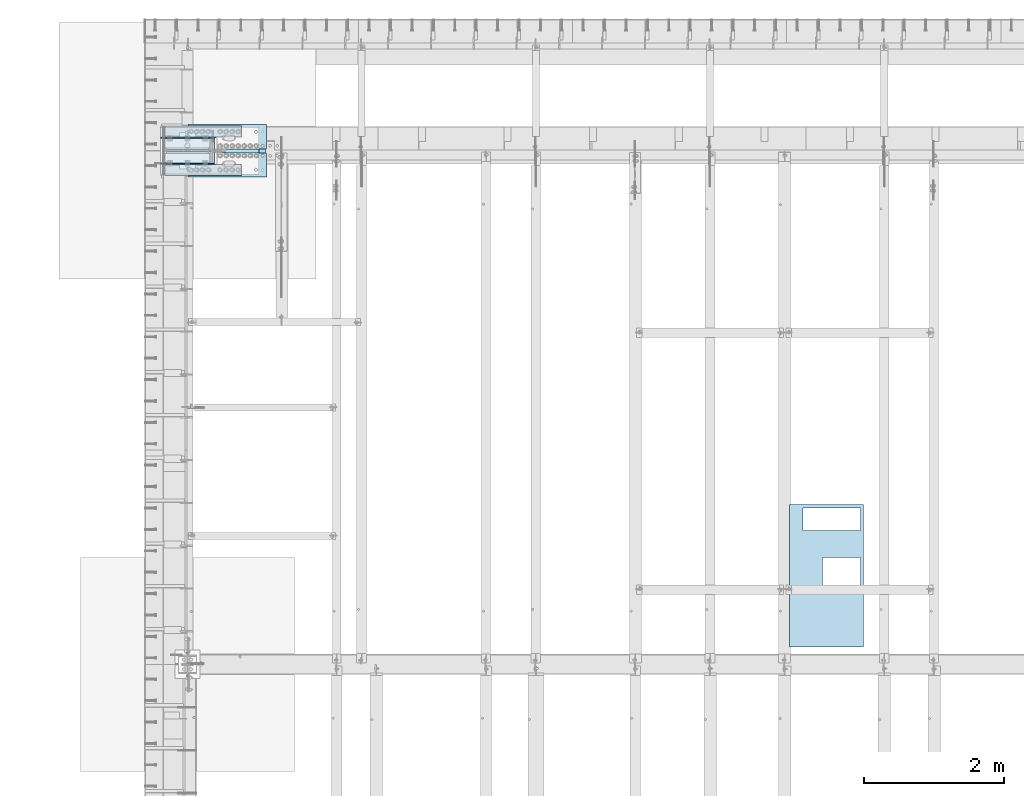
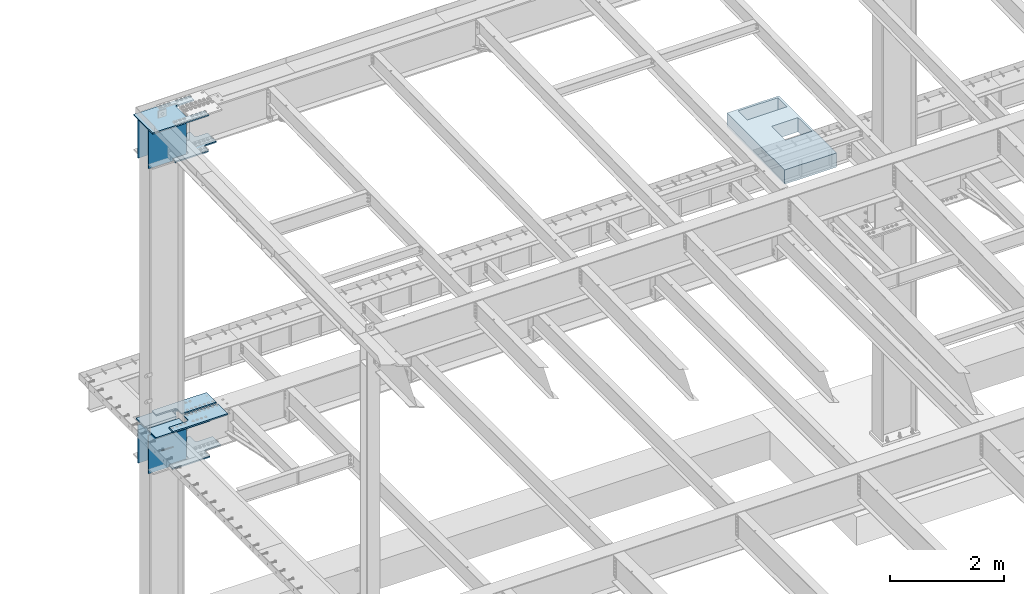
# One storey, part 1419 of 1763: 12 plates, 6 elements without a shape of their own.
"""IFC2X3 building model written with IfcOpenShell, lengths in millimetres."""

from ifc_helpers import new_model, si_unit, frame, origin_with_axes, place, context, subcontext, project, spatial, faceted_brep, material, type_object, element, aggregate, save


model = new_model("IFC2X3")

# Units and contexts
model_context = context("Model", 3, precision=1e-05, world=origin_with_axes())
body_context = subcontext(model_context, "Body", "Model", "MODEL_VIEW")
ifc_project = project(units=[si_unit("LENGTHUNIT", "METRE", prefix="MILLI"), si_unit("AREAUNIT", "SQUARE_METRE"), si_unit("VOLUMEUNIT", "CUBIC_METRE"), si_unit("MASSUNIT", "GRAM", prefix="KILO"), si_unit("TIMEUNIT", "SECOND"), si_unit("PLANEANGLEUNIT", "RADIAN"), si_unit("SOLIDANGLEUNIT", "STERADIAN"), si_unit("THERMODYNAMICTEMPERATUREUNIT", "DEGREE_CELSIUS"), si_unit("LUMINOUSINTENSITYUNIT", "LUMEN")], contexts=[model_context])

# Site, building, storey
site_placement = place(None, origin_with_axes())
site = spatial("IfcSite", under=ifc_project, at=site_placement, CompositionType="ELEMENT")
building_placement = place(site_placement, origin_with_axes())
building = spatial("IfcBuilding", under=site, at=building_placement, Name="Undefined", CompositionType="ELEMENT")
storey_placement = place(building_placement, origin_with_axes())
storey = spatial("IfcBuildingStorey", under=building, at=storey_placement, Name="Undefined", CompositionType="ELEMENT", Elevation=0.0)

# Assembly, plate
assembly_1_placement = place(storey_placement, origin_with_axes())
assembly_1 = element("IfcElementAssembly", 1, at=assembly_1_placement, inside=storey, Name="A-BOX", AssemblyPlace="NOTDEFINED", PredefinedType="RIGID_FRAME")
ifc_material_1 = material(Name="STEEL/A36")
plate_type_1 = type_object("IfcPlateType", PredefinedType="NOTDEFINED")
plate_1_placement = place(assembly_1_placement, frame((-77748.9366844177, 47081.685353399, 11747.5), z_axis=(0.0, -1.0, 0.0), x_axis=(-1.0, 0.0, 0.0)))
plate_1 = element("IfcPlate", 2, at=plate_1_placement, type_object=plate_type_1, material=ifc_material_1, Name="A-BOX", context=body_context, shape_type="Brep", body=[
    faceted_brep([(581.024999999994, -152.4, 1230.75092269852), (581.024999999994, 152.4, 1230.75092269852), (581.024999999994, 152.4, 749.303901214145), (581.024999999994, -152.4, 749.303901214145), (44.4499877929629, 152.4, 749.303901214145), (44.4499877929629, -152.4, 749.303901214145), (44.4499877929629, 152.4, 1235.07888175919), (44.4499877929629, -152.4, 1235.07888175919), (581.024999999994, 152.4, 1235.07888175919), (581.024999999994, -152.4, 1235.07888175919), (1054.09997558594, -152.4, 0.0), (0.0, -152.4, 0.0), (0.0, 152.4, 0.0), (1054.09997558594, 152.4, 0.0), (1054.09997558594, -152.4, 2025.64990234375), (1054.09997558594, 152.4, 2025.64990234375), (0.0, -152.4, 2025.64990234375), (0.0, 152.4, 2025.64990234375), (44.4499999999971, -152.4, 44.4499999999971), (44.4499999999971, -152.4, 365.128863525388), (857.241015624997, -152.4, 365.128863525388), (857.241015624997, -152.4, 44.4499999999971), (44.4499999999971, 152.4, 44.4499999999971), (44.4499999999971, 152.4, 365.128863525388), (857.241015624997, 152.4, 44.4499999999971), (857.241015624997, 152.4, 365.128863525388)], [[[0, 1, 2, 3]], [[3, 2, 4, 5]], [[5, 4, 6, 7]], [[7, 6, 8, 9]], [[9, 8, 1, 0]], [[10, 11, 12, 13]], [[14, 10, 13, 15]], [[16, 14, 15, 17]], [[11, 16, 17, 12]], [[10, 14, 16, 11], [3, 5, 7, 9, 0], [18, 19, 20, 21]], [[18, 22, 23, 19]], [[21, 24, 22, 18]], [[20, 25, 24, 21]], [[19, 23, 25, 20]], [[15, 13, 12, 17], [4, 2, 1, 8, 6], [22, 24, 25, 23]]]),
])
aggregate(assembly_1, [plate_1])

# Assembly, plates
assembly_2_placement = place(storey_placement, origin_with_axes())
assembly_2 = element("IfcElementAssembly", 3, at=assembly_2_placement, inside=storey, Name="COLUMN", AssemblyPlace="NOTDEFINED", PredefinedType="RIGID_FRAME")
ifc_material_2 = material(Name="STEEL/A572-50")
plate_type_2 = type_object("IfcPlateType", PredefinedType="NOTDEFINED")
plate_2_placement = place(assembly_2_placement, frame((-87697.6997742445, 52130.325, 5180.01249999526), z_axis=(1.0, 0.0, 0.0), x_axis=(0.0, 1.0, 0.0)))
plate_2 = element("IfcPlate", 4, at=plate_2_placement, type_object=plate_type_2, material=ifc_material_2, Name="PLATE", context=body_context, shape_type="Brep", body=[
    faceted_brep([(342.899993896484, 14.2875000000004, 0.0), (342.899993896484, -14.2875000000004, 0.0), (38.0999984740847, -14.2875000000004, 3.44835279975086e-05), (38.0999984740847, 14.2875000000004, 0.0), (342.899993896484, -14.2875000000004, 1092.20007324219), (342.899993896484, 14.2875000000004, 1092.20007324219), (184.149993896484, 14.2875000000004, 1092.20007324219), (184.149993896484, -14.2875000000004, 1092.20006477094), (184.150003540068, 14.2875000000004, 657.22498610086), (184.150003540068, -14.2875000000004, 657.22498610086), (183.183273642404, 14.2875000000004, 652.364906361428), (183.183273642404, -14.2875000000004, 652.364906361428), (180.43025961001, 14.2875000000004, 648.24472972611), (180.43025961001, -14.2875000000004, 648.24472972611), (176.310082909098, 14.2875000000004, 645.491715791897), (176.310082909098, -14.2875000000004, 645.491715791897), (171.450003146623, 14.2875000000004, 644.52498601003), (171.450003146623, -14.2875000000004, 644.52498601003), (38.1000246132753, 14.2875000056511, 644.524992143954), (38.1000246132753, -14.2875000000004, 644.524959412971), (28.5750000867774, 14.2875000059566, 634.999971765254), (7.27595761418343e-12, -14.2875000000004, 606.424995419206), (0.0, -14.2875000000004, 38.0999984772934), (28.575000080913, 14.2875000000986, 9.52499494639051)], [[[0, 1, 2, 3]], [[4, 1, 0, 5]], [[4, 5, 6, 7]], [[7, 6, 8, 9]], [[9, 8, 10, 11]], [[11, 10, 12, 13]], [[13, 12, 14, 15]], [[15, 14, 16, 17]], [[17, 16, 18, 19]], [[19, 18, 20, 21]], [[2, 1, 4, 7, 9, 11, 13, 15, 17, 19, 21, 22]], [[3, 2, 22, 23]], [[18, 16, 14, 12, 10, 8, 6, 5, 0, 3, 23, 20]], [[22, 21, 20, 23]]]),
])
plate_3_placement = place(assembly_2_placement, frame((-87697.6997742445, 52111.275, 5180.01249999526), z_axis=(1.0, 0.0, 0.0), x_axis=(0.0, -1.0, 0.0)))
plate_3 = element("IfcPlate", 5, at=plate_3_placement, type_object=plate_type_2, material=ifc_material_2, Name="PLATE", context=body_context, shape_type="Brep", body=[
    faceted_brep([(342.899993896484, 14.2875000000004, 0.0), (342.899993896484, -14.2875000000004, 0.0), (38.0999984740847, -14.2875000000004, 3.44835279975086e-05), (38.0999984740847, 14.2875000000004, 0.0), (342.899993896484, -14.2875000000004, 1092.20007324219), (342.899993896484, 14.2875000000004, 1092.20007324219), (184.149993896484, 14.2875000000004, 1092.20007324219), (184.149993896484, -14.2875000000004, 1092.20006477094), (184.150003540068, 14.2875000000004, 657.22498610086), (184.150003540068, -14.2875000000004, 657.22498610086), (183.183273642404, 14.2875000000004, 652.364906361428), (183.183273642404, -14.2875000000004, 652.364906361428), (180.43025961001, 14.2875000000004, 648.24472972611), (180.43025961001, -14.2875000000004, 648.24472972611), (176.310082909098, 14.2875000000004, 645.491715791897), (176.310082909098, -14.2875000000004, 645.491715791897), (171.450003146623, 14.2875000000004, 644.52498601003), (171.450003146623, -14.2875000000004, 644.52498601003), (38.1000246132753, 14.2875000056511, 644.524992143954), (38.1000246132753, -14.2875000000004, 644.524959412971), (28.5750000866901, -14.2875000058648, 634.9999521266), (28.5750000809203, -14.2875000000968, 9.52501563653641), (0.0, 14.2875000000004, 38.0999984772934), (7.27595761418343e-12, 14.2875000000004, 606.424995419206)], [[[0, 1, 2, 3]], [[4, 1, 0, 5]], [[4, 5, 6, 7]], [[7, 6, 8, 9]], [[9, 8, 10, 11]], [[11, 10, 12, 13]], [[13, 12, 14, 15]], [[15, 14, 16, 17]], [[17, 16, 18, 19]], [[2, 1, 4, 7, 9, 11, 13, 15, 17, 19, 20, 21]], [[3, 2, 21, 22]], [[18, 16, 14, 12, 10, 8, 6, 5, 0, 3, 22, 23]], [[19, 18, 23, 20]], [[22, 21, 20, 23]]]),
])
plate_type_3 = type_object("IfcPlateType", PredefinedType="NOTDEFINED")
plate_4_placement = place(assembly_2_placement, frame((-86615.0247736984, 51787.4250002128, 11733.2124917654), z_axis=(-1.0, 0.0, 0.0), x_axis=(0.0, 1.0, 0.0)))
plate_4 = element("IfcPlate", 6, at=plate_4_placement, type_object=plate_type_3, material=ifc_material_2, Name="PLATE", context=body_context, shape_type="Brep", body=[
    faceted_brep([(139.700000000004, -14.2875000000004, 0.0), (139.700000000004, 14.2875000000004, 0.0), (139.700000352379, 14.2875000000004, 352.425012588552), (139.700000352379, -14.2875000000004, 352.425012588552), (141.63346020726, 14.2875000000004, 362.145171622687), (141.63346020726, -14.2875000000004, 362.145171622687), (147.139488016437, 14.2875000000004, 370.38552455348), (147.139488016437, -14.2875000000004, 370.38552455348), (155.379840958223, 14.2875000000004, 375.891552346206), (155.379840958223, -14.2875000000004, 375.891552346206), (165.099999996222, 14.2875000000004, 377.825012181682), (165.099999996222, -14.2875000000004, 377.825012181682), (501.650006861608, 14.2875000000004, 377.825011846209), (501.650006861608, -14.2875000000004, 377.825011846209), (511.370165895773, 14.2875000000004, 375.891551991343), (511.370165895773, -14.2875000000004, 375.891551991343), (519.610518826594, 14.2875000000004, 370.385524182173), (519.610518826594, -14.2875000000004, 370.385524182173), (525.116546619334, 14.2875000000004, 362.14517124038), (525.116546619334, -14.2875000000004, 362.14517124038), (527.050006454818, -14.2875000000004, 352.425012202359), (527.050006454818, 14.2875000000004, 352.425012202359), (527.05000610352, 14.2875000000004, -1.45519152283669e-11), (527.05000610352, -14.2875000000004, -1.45519152283669e-11), (0.0, -14.2875000000058, 0.0), (0.0, -14.2875000000004, 1143.0), (0.0, 14.2875000000004, 1143.0), (0.0, 14.2875000000058, 0.0), (666.75, -14.2875000000004, 1143.0), (666.75, 14.2875000000004, 1143.0), (666.75, -14.2875000000004, -1.45519152283669e-11), (666.75, 14.2875000000004, -1.45519152283669e-11)], [[[0, 1, 2, 3]], [[3, 2, 4, 5]], [[5, 4, 6, 7]], [[7, 6, 8, 9]], [[9, 8, 10, 11]], [[11, 10, 12, 13]], [[13, 12, 14, 15]], [[15, 14, 16, 17]], [[17, 16, 18, 19]], [[20, 21, 22, 23]], [[19, 18, 21, 20]], [[24, 25, 26, 27]], [[25, 28, 29, 26]], [[28, 30, 31, 29]], [[31, 30, 23, 22]], [[16, 14, 12, 10, 8, 6, 4, 2, 1, 27, 26, 29, 31, 22, 21, 18]], [[24, 27, 1, 0]], [[30, 28, 25, 24, 0, 3, 5, 7, 9, 11, 13, 15, 17, 19, 20, 23]]]),
])

# Assembly, plate
assembly_3_placement = place(storey_placement, origin_with_axes())
assembly_3 = element("IfcElementAssembly", 7, at=assembly_3_placement, inside=storey, Name="PLATE", AssemblyPlace="NOTDEFINED", PredefinedType="RIGID_FRAME")
plate_type_4 = type_object("IfcPlateType", PredefinedType="NOTDEFINED")
plate_5_placement = place(assembly_3_placement, frame((-87294.4747736984, 51793.7750002128, 10955.3374917654), z_axis=(0.0, 1.0, 0.0), x_axis=(1.0, 0.0, 0.0)))
plate_5 = element("IfcPlate", 8, at=plate_5_placement, type_object=plate_type_4, material=ifc_material_2, Name="PLATE", context=body_context, shape_type="Brep", body=[
    faceted_brep([(0.0, -14.2875000000058, 0.0), (0.0, -14.2875000000004, 104.775001525879), (0.0, 14.2875000000004, 104.775001525879), (0.0, 14.2875000000058, 0.0), (300.037487030029, -14.2875000000004, 104.775001525879), (300.037487030029, 14.2875000000004, 104.775001525879), (311.320470272905, -14.2875000000004, 106.562050511995), (311.320470272905, 14.2875000000004, 106.562050511995), (321.4989965028, -14.2875000000004, 111.748268664473), (321.4989965028, 14.2875000000004, 111.748268664473), (329.576720654375, -14.2875000000004, 119.825992816048), (329.576720654375, 14.2875000000004, 119.825992816048), (334.762938806853, -14.2875000000004, 130.004519045942), (334.762938806853, 14.2875000000004, 130.004519045942), (336.549987792969, -14.2875000000004, 141.287502288818), (336.549987792969, 14.2875000000004, 141.287502288818), (336.549987792969, -14.2875000000004, 512.762523651123), (336.549987792969, 14.2875000000004, 512.762523651123), (334.762938806853, -14.2875000000004, 524.045506893999), (334.762938806853, 14.2875000000004, 524.045506893999), (329.576720654375, -14.2875000000004, 534.224033123894), (329.576720654375, 14.2875000000004, 534.224033123894), (321.4989965028, -14.2875000000004, 542.301757275469), (321.4989965028, 14.2875000000004, 542.301757275469), (311.320470272905, -14.2875000000004, 547.487975427946), (311.320470272905, 14.2875000000004, 547.487975427946), (300.037487030029, -14.2875000000004, 549.275024414062), (300.037487030029, 14.2875000000004, 549.275024414062), (0.0, -14.2875000000004, 549.275024414062), (0.0, 14.2875000000004, 549.275024414062), (0.0, -14.2875000000004, 654.049987792969), (0.0, 14.2875000000004, 654.049987792969), (679.450012207031, -14.2875000000004, 654.049987792969), (679.450012207031, 14.2875000000004, 654.049987792969), (679.450012207031, -14.2875000000004, 512.762500762939), (679.450012207031, 14.2875000000004, 512.762500762939), (681.237061193147, -14.2875000000004, 501.479517520063), (681.237061193147, 14.2875000000004, 501.479517520063), (686.423279345625, -14.2875000000004, 491.300991290169), (686.423279345625, 14.2875000000004, 491.300991290169), (694.5010034972, -14.2875000000004, 483.223267138594), (694.5010034972, 14.2875000000004, 483.223267138594), (704.679529727095, -14.2875000000004, 478.037048986116), (704.679529727095, 14.2875000000004, 478.037048986116), (715.962512969971, -14.2875000000004, 476.25), (715.962512969971, 14.2875000000004, 476.25), (936.625, -14.2875000000004, 476.25), (936.625, 14.2875000000004, 476.25), (936.625, -14.2875000000004, 177.800003051758), (936.625, 14.2875000000004, 177.800003051758), (715.962512969971, -14.2875000000004, 177.800003051758), (715.962512969971, 14.2875000000004, 177.800003051758), (704.679529727095, -14.2875000000004, 176.012954065642), (704.679529727095, 14.2875000000004, 176.012954065642), (694.5010034972, -14.2875000000004, 170.826735913164), (694.5010034972, 14.2875000000004, 170.826735913164), (686.423279345625, -14.2875000000004, 162.749011761589), (686.423279345625, 14.2875000000004, 162.749011761589), (681.237061193147, -14.2875000000004, 152.570485531694), (681.237061193147, 14.2875000000004, 152.570485531694), (679.450012207031, -14.2875000000004, 141.287502288818), (679.450012207031, 14.2875000000004, 141.287502288818), (679.450012207031, -14.2875000000004, 0.0), (679.450012207031, 14.2875000000004, 0.0)], [[[0, 1, 2, 3]], [[1, 4, 5, 2]], [[4, 6, 7, 5]], [[6, 8, 9, 7]], [[8, 10, 11, 9]], [[10, 12, 13, 11]], [[12, 14, 15, 13]], [[14, 16, 17, 15]], [[16, 18, 19, 17]], [[18, 20, 21, 19]], [[20, 22, 23, 21]], [[22, 24, 25, 23]], [[24, 26, 27, 25]], [[26, 28, 29, 27]], [[28, 30, 31, 29]], [[30, 32, 33, 31]], [[32, 34, 35, 33]], [[34, 36, 37, 35]], [[36, 38, 39, 37]], [[38, 40, 41, 39]], [[40, 42, 43, 41]], [[42, 44, 45, 43]], [[44, 46, 47, 45]], [[46, 48, 49, 47]], [[48, 50, 51, 49]], [[50, 52, 53, 51]], [[52, 54, 55, 53]], [[54, 56, 57, 55]], [[56, 58, 59, 57]], [[58, 60, 61, 59]], [[60, 62, 63, 61]], [[62, 0, 3, 63]], [[5, 7, 9, 11, 13, 15, 17, 19, 21, 23, 25, 27, 29, 31, 33, 35, 37, 39, 41, 43, 45, 47, 49, 51, 53, 55, 57, 59, 61, 63, 3, 2]], [[62, 60, 58, 56, 54, 52, 50, 48, 46, 44, 42, 40, 38, 36, 34, 32, 30, 28, 26, 24, 22, 20, 18, 16, 14, 12, 10, 8, 6, 4, 1, 0]]]),
])
aggregate(assembly_3, [plate_5])

# Plate
plate_type_5 = type_object("IfcPlateType", PredefinedType="NOTDEFINED")
plate_6_placement = place(assembly_2_placement, frame((-86992.8497859054, 52306.5375, 11718.9249917654), z_axis=(0.0, 0.0, -1.0), x_axis=(-1.0, 0.0, 0.0)))
plate_6 = element("IfcPlate", 9, at=plate_6_placement, type_object=plate_type_5, material=ifc_material_2, Name="COVER PLATE", context=body_context, shape_type="Brep", body=[
    faceted_brep([(-7.27595761418343e-12, -7.9375, 0.0), (-1.2191194400657e-05, -7.9375, 825.5), (-1.2191194400657e-05, 7.9375, 825.5), (-7.27595761418343e-12, 7.9375, 0.0), (765.174987792969, -7.9375, 825.5), (765.174987792969, 7.9375, 825.5), (765.174987792969, -7.9375, 0.0), (765.174987792969, 7.9375, 0.0)], [[[0, 1, 2, 3]], [[1, 4, 5, 2]], [[4, 6, 7, 5]], [[6, 0, 3, 7]], [[5, 7, 3, 2]], [[6, 4, 1, 0]]]),
])

plate_7_placement = place(assembly_2_placement, frame((-86992.8497859054, 51935.0625, 11718.9249917654), z_axis=(0.0, 0.0, -1.0), x_axis=(-1.0, 0.0, 0.0)))
plate_7 = element("IfcPlate", 10, at=plate_7_placement, type_object=plate_type_5, material=ifc_material_2, Name="COVER PLATE", context=body_context, shape_type="Brep", body=[
    faceted_brep([(-7.27595761418343e-12, -7.9375, 0.0), (-1.2191194400657e-05, -7.9375, 825.5), (-1.2191194400657e-05, 7.9375, 825.5), (-7.27595761418343e-12, 7.9375, 0.0), (765.174987792969, -7.9375, 825.5), (765.174987792969, 7.9375, 825.5), (765.174987792969, -7.9375, 0.0), (765.174987792969, 7.9375, 0.0)], [[[0, 1, 2, 3]], [[1, 4, 5, 2]], [[4, 6, 7, 5]], [[6, 0, 3, 7]], [[5, 7, 3, 2]], [[6, 4, 1, 0]]]),
])

plate_8_placement = place(assembly_2_placement, frame((-86992.8497736984, 52306.5375, 5165.725), z_axis=(0.0, 0.0, -1.0), x_axis=(-1.0, 0.0, 0.0)))
plate_8 = element("IfcPlate", 11, at=plate_8_placement, type_object=plate_type_5, material=ifc_material_2, Name="COVER PLATE", context=body_context, shape_type="Brep", body=[
    faceted_brep([(19.0499815529183, 7.93750682487007, 15.8750000047403), (19.0499815529183, -7.9375, 0.0), (19.0499815529183, 7.9375, 0.0), (79.37498155293, 7.93750682487007, 15.8750000047403), (79.37498155293, -7.9375, 0.0), (-7.27595761418343e-12, -7.9375, 0.0), (-7.27595761418343e-12, 7.9375, 0.0), (0.0, -7.9375, 822.324951171875), (0.0, 7.9375, 822.324951171875), (765.174987792969, -7.9375, 822.324951171875), (765.174987792969, 7.9375, 822.324951171875), (765.174987792969, -7.9375, 0.0), (765.174987792969, 7.9375, 0.0), (685.799981552918, -7.9375, 0.0), (685.799981552918, 7.9375, 0.0), (685.799981552918, 7.93750682487007, 15.8750000047403), (504.745217649033, 7.9375, 423.782724431523), (501.140063123385, 7.9375, 426.191611671965), (496.887493408227, 7.9375, 427.037500381452), (268.287496841454, 7.9375, 427.037500381452), (264.034927126311, 7.9375, 426.191611671965), (260.429772600648, 7.9375, 423.782724431523), (258.020885360209, 7.9375, 420.177569905865), (257.17499665072, 7.9375, 415.925000190718), (258.020885360209, 7.9375, 411.672430475577), (260.429772600648, 7.9375, 408.06727594992), (264.034927126311, 7.9375, 405.658388709478), (268.287496841454, 7.9375, 404.812499999991), (496.887493408227, 7.9375, 404.812499999983), (501.140063123385, 7.9375, 405.65838870947), (504.745217649033, 7.9375, 408.067275949912), (507.154104889487, 7.9375, 411.67243047557), (507.999993598962, 7.9375, 415.925000190718), (507.154104889487, 7.9375, 420.177569905865), (507.154104857837, -7.9375, 420.177569905865), (507.999993567311, -7.9375, 415.925000190718), (504.745217617383, -7.9375, 423.782724431523), (501.140063091734, -7.9375, 426.191611671965), (496.887493376576, -7.9375, 427.037500381452), (268.287496809804, -7.9375, 427.037500381452), (264.034927094661, -7.9375, 426.191611671965), (260.429772569012, -7.9375, 423.782724431523), (258.020885328559, -7.9375, 420.177569905865), (257.174996619069, -7.9375, 415.925000190718), (258.020885328559, -7.9375, 411.672430475577), (260.429772569012, -7.9375, 408.06727594992), (264.034927094661, -7.9375, 405.658388709478), (268.287496809804, -7.9375, 404.812499999991), (496.887493376576, -7.9375, 404.812499999983), (501.140063091734, -7.9375, 405.65838870947), (504.745217617383, -7.9375, 408.067275949912), (507.154104857837, -7.9375, 411.67243047557)], [[[0, 1, 2]], [[3, 4, 1, 0]], [[5, 6, 2, 1]], [[5, 7, 8, 6]], [[7, 9, 10, 8]], [[9, 11, 12, 10]], [[12, 11, 13, 14]], [[14, 13, 15]], [[2, 6, 8, 10, 12, 14, 15, 3, 0], [16, 17, 18, 19, 20, 21, 22, 23, 24, 25, 26, 27, 28, 29, 30, 31, 32, 33]], [[34, 33, 32, 35]], [[36, 16, 33, 34]], [[37, 17, 16, 36]], [[38, 18, 17, 37]], [[39, 19, 18, 38]], [[40, 20, 19, 39]], [[41, 21, 20, 40]], [[42, 22, 21, 41]], [[43, 23, 22, 42]], [[44, 24, 23, 43]], [[45, 25, 24, 44]], [[46, 26, 25, 45]], [[47, 27, 26, 46]], [[48, 28, 27, 47]], [[49, 29, 28, 48]], [[50, 30, 29, 49]], [[51, 31, 30, 50]], [[35, 32, 31, 51]], [[13, 11, 9, 7, 5, 1, 4], [50, 49, 48, 47, 46, 45, 44, 43, 42, 41, 40, 39, 38, 37, 36, 34, 35, 51]], [[15, 13, 4, 3]]]),
])

plate_9_placement = place(assembly_2_placement, frame((-86992.8497736984, 51935.0625, 5165.725), z_axis=(0.0, 0.0, -1.0), x_axis=(-1.0, 0.0, 0.0)))
plate_9 = element("IfcPlate", 12, at=plate_9_placement, type_object=plate_type_5, material=ifc_material_2, Name="COVER PLATE", context=body_context, shape_type="Brep", body=[
    faceted_brep([(19.0499815529183, -7.9375, 0.0), (19.0499815529183, 7.9375, 0.0), (19.0499815529183, -7.9374931751081, 15.8750000047348), (79.37498155293, -7.9374931751081, 15.8750000047348), (79.37498155293, 7.9375, 0.0), (-7.27595761418343e-12, -7.9375, 0.0), (-7.27595761418343e-12, 7.9375, 0.0), (0.0, -7.9375, 822.324951171875), (0.0, 7.9375, 822.324951171875), (765.174987792969, -7.9375, 822.324951171875), (765.174987792969, 7.9375, 822.324951171875), (765.174987792969, -7.9375, 0.0), (765.174987792969, 7.9375, 0.0), (685.799981552918, -7.9375, 0.0), (685.799981552918, 7.9375, 0.0), (685.799981552918, -7.9374931751081, 15.8750000047348), (504.745217649033, 7.9375, 423.782724431523), (501.140063123385, 7.9375, 426.191611671965), (496.887493408227, 7.9375, 427.037500381452), (268.287496841454, 7.9375, 427.037500381452), (264.034927126311, 7.9375, 426.191611671965), (260.429772600648, 7.9375, 423.782724431523), (258.020885360209, 7.9375, 420.177569905865), (257.17499665072, 7.9375, 415.925000190718), (258.020885360209, 7.9375, 411.672430475577), (260.429772600648, 7.9375, 408.06727594992), (264.034927126311, 7.9375, 405.658388709478), (268.287496841454, 7.9375, 404.812499999991), (496.887493408227, 7.9375, 404.812499999983), (501.140063123385, 7.9375, 405.65838870947), (504.745217649033, 7.9375, 408.067275949912), (507.154104889487, 7.9375, 411.67243047557), (507.999993598962, 7.9375, 415.925000190718), (507.154104889487, 7.9375, 420.177569905865), (507.154104857837, -7.9375, 420.177569905865), (507.999993567311, -7.9375, 415.925000190718), (504.745217617383, -7.9375, 423.782724431523), (501.140063091734, -7.9375, 426.191611671965), (496.887493376576, -7.9375, 427.037500381452), (268.287496809804, -7.9375, 427.037500381452), (264.034927094661, -7.9375, 426.191611671965), (260.429772569012, -7.9375, 423.782724431523), (258.020885328559, -7.9375, 420.177569905865), (257.174996619069, -7.9375, 415.925000190718), (258.020885328559, -7.9375, 411.672430475577), (260.429772569012, -7.9375, 408.06727594992), (264.034927094661, -7.9375, 405.658388709478), (268.287496809804, -7.9375, 404.812499999991), (496.887493376576, -7.9375, 404.812499999983), (501.140063091734, -7.9375, 405.65838870947), (504.745217617383, -7.9375, 408.067275949912), (507.154104857837, -7.9375, 411.67243047557)], [[[0, 1, 2]], [[3, 2, 1, 4]], [[5, 6, 1, 0]], [[5, 7, 8, 6]], [[7, 9, 10, 8]], [[9, 11, 12, 10]], [[12, 11, 13, 14]], [[15, 14, 13]], [[3, 4, 14, 15]], [[6, 8, 10, 12, 14, 4, 1], [16, 17, 18, 19, 20, 21, 22, 23, 24, 25, 26, 27, 28, 29, 30, 31, 32, 33]], [[34, 33, 32, 35]], [[36, 16, 33, 34]], [[37, 17, 16, 36]], [[38, 18, 17, 37]], [[39, 19, 18, 38]], [[40, 20, 19, 39]], [[41, 21, 20, 40]], [[42, 22, 21, 41]], [[43, 23, 22, 42]], [[44, 24, 23, 43]], [[45, 25, 24, 44]], [[46, 26, 25, 45]], [[47, 27, 26, 46]], [[48, 28, 27, 47]], [[49, 29, 28, 48]], [[50, 30, 29, 49]], [[51, 31, 30, 50]], [[35, 32, 31, 51]], [[15, 13, 11, 9, 7, 5, 0, 2, 3], [50, 49, 48, 47, 46, 45, 44, 43, 42, 41, 40, 39, 38, 37, 36, 34, 35, 51]]]),
])

aggregate(assembly_2, [plate_2, plate_3, plate_4, plate_6, plate_7, plate_8, plate_9])

# Assembly, plate
assembly_4_placement = place(storey_placement, origin_with_axes())
assembly_4 = element("IfcElementAssembly", 13, at=assembly_4_placement, inside=storey, Name="PLATE", AssemblyPlace="NOTDEFINED", PredefinedType="RIGID_FRAME")
plate_type_6 = type_object("IfcPlateType", PredefinedType="NOTDEFINED")
plate_10_placement = place(assembly_4_placement, frame((-87364.3247736983, 51765.2, 4405.3125), z_axis=(0.0, 1.0, 0.0), x_axis=(1.0, 0.0, 0.0)))
plate_10 = element("IfcPlate", 14, at=plate_10_placement, type_object=plate_type_6, material=ifc_material_2, Name="PLATE", context=body_context, shape_type="Brep", body=[
    faceted_brep([(0.0, -14.2875000000058, 0.0), (0.0, -14.2875000000004, 133.350006103516), (0.0, 14.2875000000004, 133.350006103516), (0.0, 14.2875000000058, 0.0), (369.887512207031, -14.2875000000004, 133.350006103516), (369.887512207031, 14.2875000000004, 133.350006103516), (382.151624171282, -14.2875000000004, 135.292450613051), (382.151624171282, 14.2875000000004, 135.292450613051), (393.215239407393, -14.2875000000004, 140.929644139258), (393.215239407393, 14.2875000000004, 140.929644139258), (401.995374171282, -14.2875000000004, 149.709778903161), (401.995374171282, 14.2875000000004, 149.709778903161), (407.632567697496, -14.2875000000004, 160.773394139258), (407.632567697496, 14.2875000000004, 160.773394139258), (409.575012207031, -14.2875000000004, 173.037506103516), (409.575012207031, 14.2875000000004, 173.037506103516), (409.575012207031, -14.2875000000004, 538.162475585938), (409.575012207031, 14.2875000000004, 538.162475585938), (407.632567697496, -14.2875000000004, 550.426587550195), (407.632567697496, 14.2875000000004, 550.426587550195), (401.995374171282, -14.2875000000004, 561.490202786292), (401.995374171282, 14.2875000000004, 561.490202786292), (393.215239407393, -14.2875000000004, 570.270337550195), (393.215239407393, 14.2875000000004, 570.270337550195), (382.151624171282, -14.2875000000004, 575.907531076402), (382.151624171282, 14.2875000000004, 575.907531076402), (369.887512207031, -14.2875000000004, 577.849975585938), (369.887512207031, 14.2875000000004, 577.849975585938), (0.0, -14.2875000000004, 577.849975585938), (0.0, 14.2875000000004, 577.849975585938), (0.0, -14.2875000000004, 711.200012207031), (0.0, 14.2875000000004, 711.200012207031), (758.825012207031, -14.2875000000004, 711.200012207031), (758.825012207031, 14.2875000000004, 711.200012207031), (758.825012207031, -14.2875000000004, 538.162506103516), (758.825012207031, 14.2875000000004, 538.162506103516), (760.767456716567, -14.2875000000004, 525.898394139258), (760.767456716567, 14.2875000000004, 525.898394139258), (766.404650242781, -14.2875000000004, 514.834778903161), (766.404650242781, 14.2875000000004, 514.834778903161), (775.18478500667, -14.2875000000004, 506.054644139258), (775.18478500667, 14.2875000000004, 506.054644139258), (786.248400242781, -14.2875000000004, 500.417450613051), (786.248400242781, 14.2875000000004, 500.417450613051), (798.512512207031, -14.2875000000004, 498.475006103516), (798.512512207031, 14.2875000000004, 498.475006103516), (1101.72497558594, -14.2875000000004, 498.475006103516), (1101.72497558594, 14.2875000000004, 498.475006103516), (1101.72497558594, -14.2875000000004, 212.725006103516), (1101.72497558594, 14.2875000000004, 212.725006103516), (798.512512207031, -14.2875000000004, 212.725006103516), (798.512512207031, 14.2875000000004, 212.725006103516), (786.248400242781, -14.2875000000004, 210.78256159398), (786.248400242781, 14.2875000000004, 210.78256159398), (775.18478500667, -14.2875000000004, 205.145368067773), (775.18478500667, 14.2875000000004, 205.145368067773), (766.404650242781, -14.2875000000004, 196.36523330387), (766.404650242781, 14.2875000000004, 196.36523330387), (760.767456716567, -14.2875000000004, 185.301618067773), (760.767456716567, 14.2875000000004, 185.301618067773), (758.825012207031, -14.2875000000004, 173.037506103516), (758.825012207031, 14.2875000000004, 173.037506103516), (758.825012207031, -14.2875000000004, 0.0), (758.825012207031, 14.2875000000004, 0.0)], [[[0, 1, 2, 3]], [[1, 4, 5, 2]], [[4, 6, 7, 5]], [[6, 8, 9, 7]], [[8, 10, 11, 9]], [[10, 12, 13, 11]], [[12, 14, 15, 13]], [[14, 16, 17, 15]], [[16, 18, 19, 17]], [[18, 20, 21, 19]], [[20, 22, 23, 21]], [[22, 24, 25, 23]], [[24, 26, 27, 25]], [[26, 28, 29, 27]], [[28, 30, 31, 29]], [[30, 32, 33, 31]], [[32, 34, 35, 33]], [[34, 36, 37, 35]], [[36, 38, 39, 37]], [[38, 40, 41, 39]], [[40, 42, 43, 41]], [[42, 44, 45, 43]], [[44, 46, 47, 45]], [[46, 48, 49, 47]], [[48, 50, 51, 49]], [[50, 52, 53, 51]], [[52, 54, 55, 53]], [[54, 56, 57, 55]], [[56, 58, 59, 57]], [[58, 60, 61, 59]], [[60, 62, 63, 61]], [[62, 0, 3, 63]], [[5, 7, 9, 11, 13, 15, 17, 19, 21, 23, 25, 27, 29, 31, 33, 35, 37, 39, 41, 43, 45, 47, 49, 51, 53, 55, 57, 59, 61, 63, 3, 2]], [[62, 60, 58, 56, 54, 52, 50, 48, 46, 44, 42, 40, 38, 36, 34, 32, 30, 28, 26, 24, 22, 20, 18, 16, 14, 12, 10, 8, 6, 4, 1, 0]]]),
])
aggregate(assembly_4, [plate_10])

assembly_5_placement = place(storey_placement, origin_with_axes())
assembly_5 = element("IfcElementAssembly", 15, at=assembly_5_placement, inside=storey, Name="TOP PLATE", AssemblyPlace="NOTDEFINED", PredefinedType="RIGID_FRAME")
plate_type_7 = type_object("IfcPlateType", PredefinedType="NOTDEFINED")
plate_11_placement = place(assembly_5_placement, frame((-86253.0747736983, 52092.225, 5208.5875), z_axis=(0.0, -1.0, 0.0), x_axis=(-1.0, 0.0, 0.0)))
plate_11 = element("IfcPlate", 16, at=plate_11_placement, type_object=plate_type_7, material=ifc_material_2, Name="TOP PLATE", context=body_context, shape_type="Brep", body=[
    faceted_brep([(0.0, -14.2875000000058, 0.0), (0.0, -14.2875000000004, 346.075012207031), (0.0, 14.2875000000004, 346.075012207031), (0.0, 14.2875000000058, 0.0), (1111.25, -14.2875000000004, 346.075012207031), (1111.25, 14.2875000000004, 346.075012207031), (1111.25, -14.2875000000004, 193.675003051758), (1111.25, 14.2875000000004, 193.675003051758), (749.299987792969, -14.2875000000004, 193.675003051758), (749.299987792969, 14.2875000000004, 193.675003051758), (731.074689326575, -14.2875000000004, 190.049765787611), (731.074689326575, 14.2875000000004, 190.049765787611), (715.624027338956, -14.2875000000004, 179.725963505771), (715.624027338956, 14.2875000000004, 179.725963505771), (705.300225057115, -14.2875000000004, 164.275301518144), (705.300225057115, 14.2875000000004, 164.275301518144), (701.674987792969, -14.2875000000004, 146.050003051758), (701.674987792969, 14.2875000000004, 146.050003051758), (701.674987792969, -14.2875000000004, 0.0), (701.674987792969, 14.2875000000004, 0.0)], [[[0, 1, 2, 3]], [[1, 4, 5, 2]], [[4, 6, 7, 5]], [[6, 8, 9, 7]], [[8, 10, 11, 9]], [[10, 12, 13, 11]], [[12, 14, 15, 13]], [[14, 16, 17, 15]], [[16, 18, 19, 17]], [[18, 0, 3, 19]], [[5, 7, 9, 11, 13, 15, 17, 19, 3, 2]], [[18, 16, 14, 12, 10, 8, 6, 4, 1, 0]]]),
])
aggregate(assembly_5, [plate_11])

assembly_6_placement = place(storey_placement, origin_with_axes())
assembly_6 = element("IfcElementAssembly", 17, at=assembly_6_placement, inside=storey, Name="TOP PLATE", AssemblyPlace="NOTDEFINED", PredefinedType="RIGID_FRAME")
plate_12_placement = place(assembly_6_placement, frame((-86954.7497736983, 52149.375, 5208.5875), z_axis=(0.0, 1.0, 0.0), x_axis=(1.0, 0.0, 0.0)))
plate_12 = element("IfcPlate", 18, at=plate_12_placement, type_object=plate_type_7, material=ifc_material_2, Name="TOP PLATE", context=body_context, shape_type="Brep", body=[
    faceted_brep([(0.0, -14.2875000000058, 0.0), (0.0, -14.2875000000004, 146.050003051758), (0.0, 14.2875000000004, 146.050003051758), (0.0, 14.2875000000058, 0.0), (-3.62523726414656, -14.2875000000004, 164.275301518144), (-3.62523726414656, 14.2875000000004, 164.275301518144), (-13.949039545987, -14.2875000000004, 179.725963505771), (-13.949039545987, 14.2875000000004, 179.725963505771), (-29.3997015336063, -14.2875000000004, 190.049765787611), (-29.3997015336063, 14.2875000000004, 190.049765787611), (-47.625, -14.2875000000004, 193.675003051758), (-47.625, 14.2875000000004, 193.675003051758), (-409.575012207031, -14.2875000000004, 193.675003051758), (-409.575012207031, 14.2875000000004, 193.675003051758), (-409.575012207031, -14.2875000000004, 346.075012207031), (-409.575012207031, 14.2875000000004, 346.075012207031), (701.674987792969, -14.2875000000004, 346.075012207031), (701.674987792969, 14.2875000000004, 346.075012207031), (701.674987792969, -14.2875000000004, 0.0), (701.674987792969, 14.2875000000004, 0.0)], [[[0, 1, 2, 3]], [[1, 4, 5, 2]], [[4, 6, 7, 5]], [[6, 8, 9, 7]], [[8, 10, 11, 9]], [[10, 12, 13, 11]], [[12, 14, 15, 13]], [[14, 16, 17, 15]], [[16, 18, 19, 17]], [[18, 0, 3, 19]], [[5, 7, 9, 11, 13, 15, 17, 19, 3, 2]], [[18, 16, 14, 12, 10, 8, 6, 4, 1, 0]]]),
])
aggregate(assembly_6, [plate_12])

save(model, "model.ifc")
